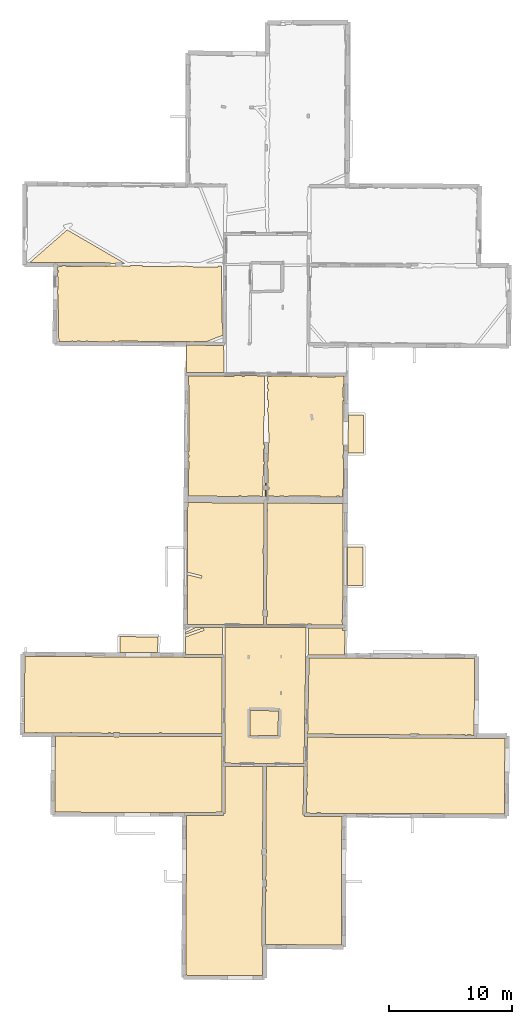
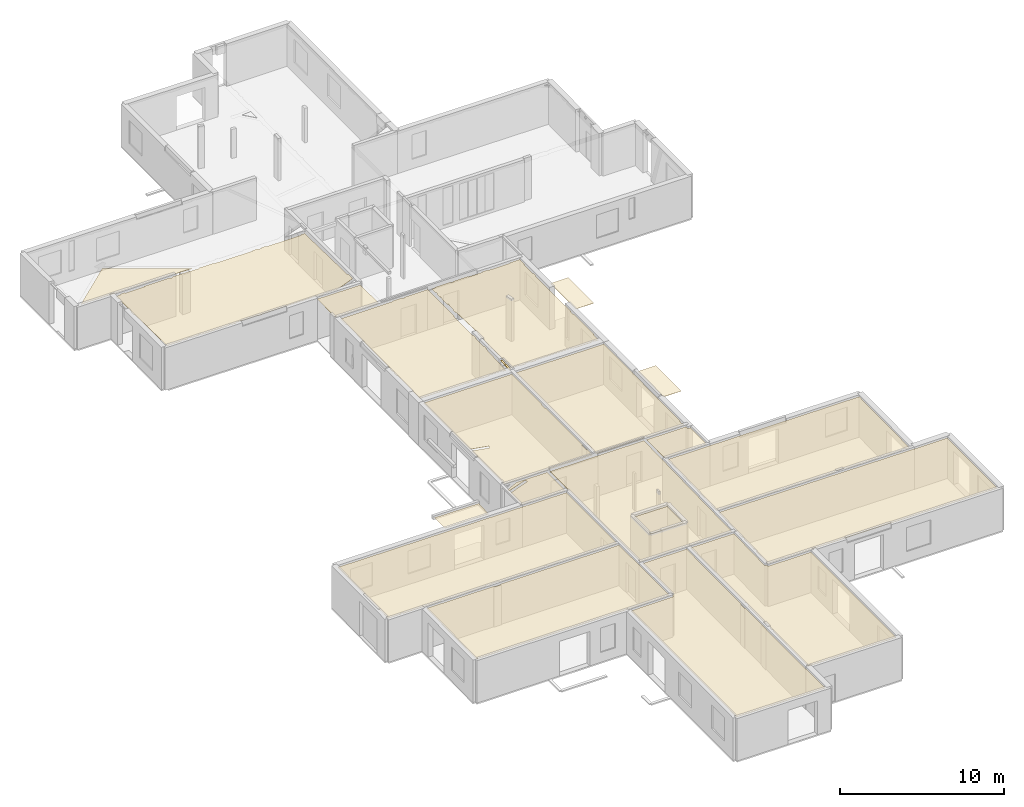
# One storey, part 10 of 14: 21 coverings.
"""IFC2X3 building model written with IfcOpenShell, lengths in metres."""

from ifc_helpers import new_model, entity, si_unit, converted_unit, derived_unit, direction, frame, origin, origin_with_axes, place, context, subcontext, project, spatial, polyline, outline, extrude, material, layer, layer_set, layer_usage, type_object, element, save


model = new_model("IFC2X3")

# Units and contexts
model_context = context("Model", 3, precision=1e-05, world=origin(), true_north=direction((0.0, 1.0)))
body_context = subcontext(model_context, "Body", "Model", "MODEL_VIEW")
ifc_project = project(units=[si_unit("LENGTHUNIT", "METRE"), si_unit("AREAUNIT", "SQUARE_METRE"), si_unit("VOLUMEUNIT", "CUBIC_METRE"), converted_unit("PLANEANGLEUNIT", "DEGREE", entity("IfcRatioMeasure", 0.0174532925199433), si_unit("PLANEANGLEUNIT", "RADIAN"), dimensions=[0, 0, 0, 0, 0, 0, 0]), si_unit("MASSUNIT", "GRAM", prefix="KILO"), derived_unit("MASSDENSITYUNIT", [(si_unit("MASSUNIT", "GRAM", prefix="KILO"), 1), (si_unit("LENGTHUNIT", "METRE"), -3)]), derived_unit("MOMENTOFINERTIAUNIT", [(si_unit("LENGTHUNIT", "METRE"), 4)]), si_unit("TIMEUNIT", "SECOND"), si_unit("FREQUENCYUNIT", "HERTZ"), si_unit("THERMODYNAMICTEMPERATUREUNIT", "DEGREE_CELSIUS"), derived_unit("THERMALTRANSMITTANCEUNIT", [(si_unit("MASSUNIT", "GRAM", prefix="KILO"), 1), (si_unit("THERMODYNAMICTEMPERATUREUNIT", "KELVIN"), -1), (si_unit("TIMEUNIT", "SECOND"), -3)]), derived_unit("VOLUMETRICFLOWRATEUNIT", [(si_unit("LENGTHUNIT", "METRE"), 3), (si_unit("TIMEUNIT", "SECOND"), -1)]), si_unit("ELECTRICCURRENTUNIT", "AMPERE"), si_unit("ELECTRICVOLTAGEUNIT", "VOLT"), si_unit("POWERUNIT", "WATT"), si_unit("FORCEUNIT", "NEWTON", prefix="KILO"), si_unit("ILLUMINANCEUNIT", "LUX"), si_unit("LUMINOUSFLUXUNIT", "LUMEN"), si_unit("LUMINOUSINTENSITYUNIT", "CANDELA"), derived_unit("USERDEFINED", [(si_unit("MASSUNIT", "GRAM", prefix="KILO"), -1), (si_unit("LENGTHUNIT", "METRE"), -2), (si_unit("TIMEUNIT", "SECOND"), 3), (si_unit("LUMINOUSFLUXUNIT", "LUMEN"), 1)]), derived_unit("LINEARVELOCITYUNIT", [(si_unit("LENGTHUNIT", "METRE"), 1), (si_unit("TIMEUNIT", "SECOND"), -1)]), si_unit("PRESSUREUNIT", "PASCAL"), derived_unit("USERDEFINED", [(si_unit("LENGTHUNIT", "METRE"), -2), (si_unit("MASSUNIT", "GRAM", prefix="KILO"), 1), (si_unit("TIMEUNIT", "SECOND"), -2)]), derived_unit("LINEARFORCEUNIT", [(si_unit("MASSUNIT", "GRAM", prefix="KILO"), 1), (si_unit("LENGTHUNIT", "METRE"), 1), (si_unit("TIMEUNIT", "SECOND"), -2), (si_unit("LENGTHUNIT", "METRE"), -1)]), derived_unit("PLANARFORCEUNIT", [(si_unit("MASSUNIT", "GRAM", prefix="KILO"), 1), (si_unit("LENGTHUNIT", "METRE"), 1), (si_unit("TIMEUNIT", "SECOND"), -2), (si_unit("LENGTHUNIT", "METRE"), -2)])], contexts=[model_context])

# Site, building, storey
placement = place(None, origin())
site = spatial("IfcSite", under=ifc_project, at=placement, CompositionType="ELEMENT")
building = spatial("IfcBuilding", under=site, at=placement, CompositionType="ELEMENT")
storey_placement = place(placement, frame((0.0, 0.0, 8.83152770996094)))
storey = spatial("IfcBuildingStorey", under=building, at=storey_placement, Name="Level 4", CompositionType="ELEMENT", Elevation=8.83152770996094)

# Coverings
ifc_material = material(Name="Covering default")
ifc_layer_1 = layer(ifc_material, 0.02)
ifc_layer_set_1 = layer_set([ifc_layer_1], Name="Covering : 20mm")
ifc_layer_usage_1 = layer_usage(ifc_layer_set_1, "AXIS3", "POSITIVE", 0.0)
covering_type_1 = type_object("IfcCoveringType", Name="Covering : 20mm", PredefinedType="CEILING")
covering_1_placement = place(placement, frame((0.0, 0.0, 11.8186979293823)))
element("IfcCovering", 1, at=covering_1_placement, inside=storey, type_object=covering_type_1, material=ifc_layer_usage_1, Name="Covering : 20mm", ObjectType="Covering : 20mm", PredefinedType="CEILING", context=body_context, shape_type="SweptSolid", body=[
    extrude(outline(polyline([(-0.155963897705078, 12.9070825576782), (2.83159446716309, 12.9335193634033), (2.83049011230469, 13.0585117340088), (2.95548820495605, 13.0584602355957), (2.95707321166992, 16.910701751709), (6.06137657165527, 16.894962310791), (6.02203750610352, 10.1598663330078), (5.96693229675293, 10.1598796844482), (5.96683120727539, 9.70976448059082), (6.0194091796875, 9.70975208282471), (5.97587585449219, 2.256667137146), (6.00043487548828, 2.25652360916138), (6.01150131225586, -0.0954488515853882), (-0.208127975463867, -0.060215950012207), (-0.155963897705078, 12.9070825576782)])), origin_with_axes(), (0.0, 0.0, 1.0), 0.02),
])
ifc_layer_2 = layer(ifc_material, 0.02)
ifc_layer_set_2 = layer_set([ifc_layer_2], Name="Covering : 20mm")
ifc_layer_usage_2 = layer_usage(ifc_layer_set_2, "AXIS3", "POSITIVE", 0.0)
covering_type_2 = type_object("IfcCoveringType", Name="Covering : 20mm", PredefinedType="CEILING")
covering_2_placement = place(placement, frame((0.0, 0.0, 11.8186979293823)))
element("IfcCovering", 2, at=covering_2_placement, inside=storey, type_object=covering_type_2, material=ifc_layer_usage_2, Name="Covering : 20mm", ObjectType="Covering : 20mm", PredefinedType="CEILING", context=body_context, shape_type="SweptSolid", body=[
    extrude(outline(polyline([(6.27205848693848, 6.73828887939453), (6.33028984069824, 6.74085998535156), (6.32365798950195, 6.89104843139648), (6.2729377746582, 6.88880920410156), (6.27441215515137, 7.14135360717773), (6.33842849731445, 7.14153099060059), (6.33696937561035, 7.66652870178223), (6.27747917175293, 7.66636371612549), (6.29000473022461, 9.81093883514404), (6.34920310974121, 9.81120872497559), (6.34751129150391, 10.1813430786133), (6.29216766357422, 10.1810903549194), (6.33137512207031, 16.8935928344727), (9.37964820861816, 16.8781394958496), (9.31031799316406, 12.9712085723877), (9.4402961730957, 12.9689025878906), (9.43974494934082, 12.838906288147), (12.454761505127, 12.8261156082153), (12.4285430908203, 2.39703178405762), (6.24689483642578, 2.43015265464783), (6.27205848693848, 6.73828887939453)])), origin_with_axes(), (0.0, 0.0, 1.0), 0.02),
])
ifc_layer_3 = layer(ifc_material, 0.02)
ifc_layer_set_3 = layer_set([ifc_layer_3], Name="Covering : 20mm")
ifc_layer_usage_3 = layer_usage(ifc_layer_set_3, "AXIS3", "POSITIVE", 0.0)
covering_type_3 = type_object("IfcCoveringType", Name="Covering : 20mm", PredefinedType="CEILING")
covering_3_placement = place(placement, frame((0.0, 0.0, 11.8186979293823)))
element("IfcCovering", 3, at=covering_3_placement, inside=storey, type_object=covering_type_3, material=ifc_layer_usage_3, Name="Covering : 20mm", ObjectType="Covering : 20mm", PredefinedType="CEILING", context=body_context, shape_type="SweptSolid", body=[
    extrude(outline(polyline([(9.59872245788574, 14.5694799423218), (9.65679931640625, 14.5681762695312), (9.66263389587402, 14.8281135559082), (9.60333442687988, 14.8294448852539), (9.62551307678223, 16.0792598724365), (9.68069076538086, 16.0780220031738), (9.68540191650391, 16.2879695892334), (9.62923812866211, 16.2892303466797), (9.6396369934082, 16.8751926422119), (9.6396369934082, 16.8751926422119), (9.68232154846191, 19.2805633544922), (23.3825645446777, 19.1745700836182), (23.3826789855957, 19.1582412719727), (25.6990547180176, 19.1746616363525), (25.6725120544434, 13.0359268188477), (12.6406917572021, 13.088828086853), (12.6406784057617, 13.0853290557861), (10.7439727783203, 13.0933752059937), (10.745096206665, 13.1433906555176), (10.4551696777344, 13.1499004364014), (10.4539279937744, 13.0946054458618), (9.57261657714844, 13.0983448028564), (9.59872245788574, 14.5694799423218)])), origin_with_axes(), (0.0, 0.0, 1.0), 0.02),
])
ifc_layer_4 = layer(ifc_material, 0.02)
ifc_layer_set_4 = layer_set([ifc_layer_4], Name="Covering : 20mm")
ifc_layer_usage_4 = layer_usage(ifc_layer_set_4, "AXIS3", "POSITIVE", 0.0)
covering_type_4 = type_object("IfcCoveringType", Name="Covering : 20mm", PredefinedType="CEILING")
covering_4_placement = place(placement, frame((0.0, 0.0, 11.8186979293823)))
element("IfcCovering", 4, at=covering_4_placement, inside=storey, type_object=covering_type_4, material=ifc_layer_usage_4, Name="Covering : 20mm", ObjectType="Covering : 20mm", PredefinedType="CEILING", context=body_context, shape_type="SweptSolid", body=[
    extrude(outline(polyline([(-10.81067943573, 19.3569412231445), (-6.06138038635254, 19.3415775299072), (-6.06136512756348, 19.2821311950684), (-5.62125015258789, 19.2822532653809), (-5.62126636505127, 19.3401546478271), (2.70806121826172, 19.3132095336914), (2.70707321166992, 16.9113903045654), (2.70553970336914, 13.1824140548706), (0.276535034179688, 13.1609201431274), (-10.8574066162109, 13.1824493408203), (-10.81067943573, 19.3569412231445)])), origin_with_axes(), (0.0, 0.0, 1.0), 0.02),
])
ifc_layer_5 = layer(ifc_material, 0.02)
ifc_layer_set_5 = layer_set([ifc_layer_5], Name="Covering : 20mm")
ifc_layer_usage_5 = layer_usage(ifc_layer_set_5, "AXIS3", "POSITIVE", 0.0)
covering_type_5 = type_object("IfcCoveringType", Name="Covering : 20mm", PredefinedType="CEILING")
covering_5_placement = place(placement, frame((0.0, 0.0, 11.8186979293823)))
element("IfcCovering", 5, at=covering_5_placement, inside=storey, type_object=covering_type_5, material=ifc_layer_usage_5, Name="Covering : 20mm", ObjectType="Covering : 20mm", PredefinedType="CEILING", context=body_context, shape_type="SweptSolid", body=[
    extrude(outline(polyline([(2.96075439453125, 25.868558883667), (2.98182487487793, 25.8685779571533), (2.97969818115234, 28.1927013397217), (9.56144332885742, 28.1640510559082), (9.38408279418945, 17.1281185150146), (2.95717620849609, 17.1607036590576), (2.96075439453125, 25.868558883667)])), origin_with_axes(), (0.0, 0.0, 1.0), 0.02),
])
ifc_layer_6 = layer(ifc_material, 0.02)
ifc_layer_set_6 = layer_set([ifc_layer_6], Name="Covering : 20mm")
ifc_layer_usage_6 = layer_usage(ifc_layer_set_6, "AXIS3", "POSITIVE", 0.0)
covering_type_6 = type_object("IfcCoveringType", Name="Covering : 20mm", PredefinedType="CEILING")
covering_6_placement = place(placement, frame((0.0, 0.0, 11.8186979293823)))
element("IfcCovering", 6, at=covering_6_placement, inside=storey, type_object=covering_type_6, material=ifc_layer_usage_6, Name="Covering : 20mm", ObjectType="Covering : 20mm", PredefinedType="CEILING", context=body_context, shape_type="SweptSolid", body=[
    extrude(outline(polyline([(5.00181007385254, 21.4414443969727), (7.30773162841797, 21.4125595092773), (7.27487182617188, 19.4015445709229), (5.64736175537109, 19.4281883239746), (5.64658546447754, 19.3807334899902), (4.9884204864502, 19.3916854858398), (5.00181007385254, 21.4414443969727)])), origin_with_axes(), (0.0, 0.0, 1.0), 0.02),
])
ifc_layer_7 = layer(ifc_material, 0.02)
ifc_layer_set_7 = layer_set([ifc_layer_7], Name="Covering : 20mm")
ifc_layer_usage_7 = layer_usage(ifc_layer_set_7, "AXIS3", "POSITIVE", 0.0)
covering_type_7 = type_object("IfcCoveringType", Name="Covering : 20mm", PredefinedType="CEILING")
covering_7_placement = place(placement, frame((0.0, 0.0, 11.8186979293823)))
element("IfcCovering", 7, at=covering_7_placement, inside=storey, type_object=covering_type_7, material=ifc_layer_usage_7, Name="Covering : 20mm", ObjectType="Covering : 20mm", PredefinedType="CEILING", context=body_context, shape_type="SweptSolid", body=[
    extrude(outline(polyline([(9.7962532043457, 25.7008686065674), (14.1999778747559, 25.6868343353271), (14.1999797821045, 25.6868343353271), (23.2475814819336, 25.6515769958496), (23.196662902832, 19.4260158538818), (22.9592170715332, 19.4278526306152), (22.9604072570801, 19.4808349609375), (22.6604804992676, 19.4875679016113), (22.6591911315918, 19.4301738739014), (22.4491806030273, 19.4317989349365), (22.4503135681152, 19.4822864532471), (22.1803779602051, 19.4883460998535), (22.1791572570801, 19.4338874816895), (21.3607063293457, 19.4402198791504), (21.3603591918945, 19.496753692627), (21.0102233886719, 19.4946098327637), (21.0105400085449, 19.4429302215576), (18.7023429870605, 19.460786819458), (18.7101287841797, 19.5162391662598), (18.5406227111816, 19.5400466918945), (18.5410270690918, 19.5429286956787), (18.0117454528809, 19.5519466400146), (18.0102844238281, 19.4661407470703), (11.6514549255371, 19.5153369903564), (11.6496639251709, 19.5747108459473), (11.4594860076904, 19.568977355957), (11.4610595703125, 19.516809463501), (9.68675804138184, 19.5305366516113), (9.7962532043457, 25.7008686065674)])), origin_with_axes(), (0.0, 0.0, 1.0), 0.02),
])
ifc_layer_8 = layer(ifc_material, 0.02)
ifc_layer_set_8 = layer_set([ifc_layer_8], Name="Covering : 20mm")
ifc_layer_usage_8 = layer_usage(ifc_layer_set_8, "AXIS3", "POSITIVE", 0.0)
covering_type_8 = type_object("IfcCoveringType", Name="Covering : 20mm", PredefinedType="CEILING")
covering_8_placement = place(placement, frame((0.0, 0.0, 11.8186979293823)))
element("IfcCovering", 8, at=covering_8_placement, inside=storey, type_object=covering_type_8, material=ifc_layer_usage_8, Name="Covering : 20mm", ObjectType="Covering : 20mm", PredefinedType="CEILING", context=body_context, shape_type="SweptSolid", body=[
    extrude(outline(polyline([(-13.3229026794434, 20.5661697387695), (-13.326681137085, 20.5662136077881), (-13.3170280456543, 21.3954544067383), (-13.3170280456543, 21.3954544067383), (-13.304967880249, 22.4314136505127), (-13.3096876144409, 22.431468963623), (-13.2855701446533, 25.8356418609619), (-0.348600387573242, 25.7713623046875), (-0.348663330078125, 25.7620182037354), (2.71070289611816, 25.7442874908447), (2.70816230773926, 19.5632095336914), (-2.18372440338135, 19.5790348052979), (-2.18246364593506, 19.6351623535156), (-2.35242080688477, 19.6389770507812), (-2.3537540435791, 19.5795841217041), (-5.59330368041992, 19.5900650024414), (-5.59317684173584, 19.6417121887207), (-6.09327411651611, 19.6429386138916), (-6.09340000152588, 19.591682434082), (-6.32446670532227, 19.5924301147461), (-6.32321643829346, 19.648099899292), (-6.4931755065918, 19.6519165039062), (-6.49449872970581, 19.5929794311523), (-9.44502830505371, 19.6025238037109), (-9.44377994537354, 19.6581382751465), (-9.62373447418213, 19.6621780395508), (-9.62506103515625, 19.6031074523926), (-10.9849128723145, 19.6075057983398), (-10.9849081039429, 19.6135864257812), (-12.2721118927002, 19.6145000457764), (-12.2741870880127, 19.6716651916504), (-12.4443702697754, 19.6654853820801), (-12.4425230026245, 19.6146202087402), (-13.3296403884888, 19.6152496337891), (-13.3229026794434, 20.5661697387695)])), origin_with_axes(), (0.0, 0.0, 1.0), 0.02),
])
ifc_layer_9 = layer(ifc_material, 0.02)
ifc_layer_set_9 = layer_set([ifc_layer_9], Name="Covering : 20mm")
ifc_layer_usage_9 = layer_usage(ifc_layer_set_9, "AXIS3", "POSITIVE", 0.0)
covering_type_9 = type_object("IfcCoveringType", Name="Covering : 20mm", PredefinedType="CEILING")
covering_9_placement = place(placement, frame((0.0, 0.0, 11.8186979293823)))
element("IfcCovering", 9, at=covering_9_placement, inside=storey, type_object=covering_type_9, material=ifc_layer_usage_9, Name="Covering : 20mm", ObjectType="Covering : 20mm", PredefinedType="CEILING", context=body_context, shape_type="SweptSolid", body=[
    extrude(outline(polyline([(9.76144981384277, 28.1631813049316), (12.5226249694824, 28.1511631011963), (12.5216178894043, 27.9413242340088), (12.7016181945801, 27.9404602050781), (12.6920166015625, 25.9410209655762), (9.73227882385254, 25.9510879516602), (9.76144981384277, 28.1631813049316)])), origin_with_axes(), (0.0, 0.0, 1.0), 0.02),
])
ifc_layer_10 = layer(ifc_material, 0.02)
ifc_layer_set_10 = layer_set([ifc_layer_10], Name="Covering : 20mm")
ifc_layer_usage_10 = layer_usage(ifc_layer_set_10, "AXIS3", "POSITIVE", 0.0)
covering_type_10 = type_object("IfcCoveringType", Name="Covering : 20mm", PredefinedType="CEILING")
covering_10_placement = place(placement, frame((0.0, 0.0, 11.8186979293823)))
element("IfcCovering", 10, at=covering_10_placement, inside=storey, type_object=covering_type_10, material=ifc_layer_usage_10, Name="Covering : 20mm", ObjectType="Covering : 20mm", PredefinedType="CEILING", context=body_context, shape_type="SweptSolid", body=[
    extrude(outline(polyline([(-0.253894805908203, 27.4120845794678), (1.26633834838867, 27.9529819488525), (1.19929504394531, 28.1414108276367), (-0.253332138061523, 27.6245670318604), (-0.252902984619141, 27.7869739532471), (0.627913475036621, 28.202938079834), (2.77969741821289, 28.1935710906982), (2.78170967102051, 25.9939556121826), (-0.257606506347656, 26.0082588195801), (-0.253894805908203, 27.4120845794678)])), origin_with_axes(), (0.0, 0.0, 1.0), 0.02),
])
ifc_layer_11 = layer(ifc_material, 0.02)
ifc_layer_set_11 = layer_set([ifc_layer_11], Name="Covering : 20mm")
ifc_layer_usage_11 = layer_usage(ifc_layer_set_11, "AXIS3", "POSITIVE", 0.0)
covering_type_11 = type_object("IfcCoveringType", Name="Covering : 20mm", PredefinedType="CEILING")
covering_11_placement = place(placement, frame((0.0, 0.0, 11.8186979293823)))
element("IfcCovering", 11, at=covering_11_placement, inside=storey, type_object=covering_type_11, material=ifc_layer_usage_11, Name="Covering : 20mm", ObjectType="Covering : 20mm", PredefinedType="CEILING", context=body_context, shape_type="SweptSolid", body=[
    extrude(outline(polyline([(-5.56164360046387, 27.446361541748), (-2.47794914245605, 27.4143123626709), (-2.50628566741943, 26.1520862579346), (-5.57108402252197, 26.1673145294189), (-5.56164360046387, 27.446361541748)])), origin_with_axes(), (0.0, 0.0, 1.0), 0.02),
])
ifc_layer_12 = layer(ifc_material, 0.02)
ifc_layer_set_12 = layer_set([ifc_layer_12], Name="Covering : 20mm")
ifc_layer_usage_12 = layer_usage(ifc_layer_set_12, "AXIS3", "POSITIVE", 0.0)
covering_type_12 = type_object("IfcCoveringType", Name="Covering : 20mm", PredefinedType="CEILING")
covering_12_placement = place(placement, frame((0.0, 0.0, 11.8186979293823)))
element("IfcCovering", 12, at=covering_12_placement, inside=storey, type_object=covering_type_12, material=ifc_layer_usage_12, Name="Covering : 20mm", ObjectType="Covering : 20mm", PredefinedType="CEILING", context=body_context, shape_type="SweptSolid", body=[
    extrude(outline(polyline([(6.35177612304688, 29.0747890472412), (6.41155433654785, 29.0746650695801), (6.41255378723145, 29.5647678375244), (6.35304832458496, 29.5648899078369), (6.37395286560059, 37.6245307922363), (6.43348693847656, 37.6263275146484), (6.42775344848633, 37.8165054321289), (6.37444686889648, 37.8148994445801), (6.37568855285645, 38.2935676574707), (12.5711727142334, 38.2620429992676), (12.5259799957275, 28.8497943878174), (12.4680080413818, 28.8486804962158), (12.4726181030273, 28.6085186004639), (12.5248260498047, 28.6095218658447), (12.5237770080566, 28.3911590576172), (9.97736167907715, 28.4022445678711), (9.9785327911377, 28.4544525146484), (9.66630172729492, 28.461462020874), (9.66500282287598, 28.4036026000977), (6.35007286071777, 28.4180316925049), (6.35177612304688, 29.0747890472412)])), origin_with_axes(), (0.0, 0.0, 1.0), 0.02),
])
ifc_layer_13 = layer(ifc_material, 0.02)
ifc_layer_set_13 = layer_set([ifc_layer_13], Name="Covering : 20mm")
ifc_layer_usage_13 = layer_usage(ifc_layer_set_13, "AXIS3", "POSITIVE", 0.0)
covering_type_13 = type_object("IfcCoveringType", Name="Covering : 20mm", PredefinedType="CEILING")
covering_13_placement = place(placement, frame((0.0, 0.0, 11.8186979293823)))
element("IfcCovering", 13, at=covering_13_placement, inside=storey, type_object=covering_type_13, material=ifc_layer_usage_13, Name="Covering : 20mm", ObjectType="Covering : 20mm", PredefinedType="CEILING", context=body_context, shape_type="SweptSolid", body=[
    extrude(outline(polyline([(-0.0705327987670898, 32.4649963378906), (1.04975509643555, 32.1874237060547), (1.09785461425781, 32.3815536499023), (-0.0699882507324219, 32.6709060668945), (-0.0550336837768555, 38.3262901306152), (6.12569046020508, 38.2948379516602), (6.11611366271973, 34.6026878356934), (6.06555938720703, 34.6038246154785), (6.05523681640625, 34.1439399719238), (6.11491966247559, 34.1426010131836), (6.10319709777832, 29.6228675842285), (6.04376792907715, 29.6230583190918), (6.04209518432617, 29.1029644012451), (6.10184669494629, 29.1027717590332), (6.10007286071777, 28.4191207885742), (-0.0811595916748047, 28.4460258483887), (-0.0705327987670898, 32.4649963378906)])), origin_with_axes(), (0.0, 0.0, 1.0), 0.02),
])
ifc_layer_14 = layer(ifc_material, 0.02)
ifc_layer_set_14 = layer_set([ifc_layer_14], Name="Covering : 20mm")
ifc_layer_usage_14 = layer_usage(ifc_layer_set_14, "AXIS3", "POSITIVE", 0.0)
covering_type_14 = type_object("IfcCoveringType", Name="Covering : 20mm", PredefinedType="CEILING")
covering_14_placement = place(placement, frame((0.0, 0.0, 11.8186979293823)))
element("IfcCovering", 14, at=covering_14_placement, inside=storey, type_object=covering_type_14, material=ifc_layer_usage_14, Name="Covering : 20mm", ObjectType="Covering : 20mm", PredefinedType="CEILING", context=body_context, shape_type="SweptSolid", body=[
    extrude(outline(polyline([(12.934103012085, 34.7059059143066), (14.1822776794434, 34.7071304321289), (14.1731395721436, 31.5940799713135), (12.9191722869873, 31.596227645874), (12.934103012085, 34.7059059143066)])), origin_with_axes(), (0.0, 0.0, 1.0), 0.02),
])
ifc_layer_15 = layer(ifc_material, 0.02)
ifc_layer_set_15 = layer_set([ifc_layer_15], Name="Covering : 20mm")
ifc_layer_usage_15 = layer_usage(ifc_layer_set_15, "AXIS3", "POSITIVE", 0.0)
covering_type_15 = type_object("IfcCoveringType", Name="Covering : 20mm", PredefinedType="CEILING")
covering_15_placement = place(placement, frame((0.0, 0.0, 11.8186979293823)))
element("IfcCovering", 15, at=covering_15_placement, inside=storey, type_object=covering_type_15, material=ifc_layer_usage_15, Name="Covering : 20mm", ObjectType="Covering : 20mm", PredefinedType="CEILING", context=body_context, shape_type="SweptSolid", body=[
    extrude(outline(polyline([(6.38441848754883, 41.6593704223633), (6.44395446777344, 41.6571044921875), (6.46832847595215, 42.2970542907715), (6.48248863220215, 42.2969131469727), (6.49119567871094, 43.1635208129883), (6.54782485961914, 43.1651573181152), (6.47463989257812, 45.697437286377), (6.42453193664551, 45.695987701416), (6.4252758026123, 46.0077819824219), (6.48159790039062, 46.0073585510254), (6.48663711547852, 46.6774139404297), (6.4268741607666, 46.677864074707), (6.42850112915039, 47.3588905334473), (6.48190307617188, 47.3576927185059), (6.48616790771484, 47.5476455688477), (6.428955078125, 47.5489311218262), (6.42990875244141, 47.9490051269531), (6.48514556884766, 47.9477653503418), (6.48896217346191, 48.1177253723145), (6.4303150177002, 48.1190414428711), (6.43136405944824, 48.5586242675781), (6.73922538757324, 48.5722236633301), (6.73690795898438, 48.6246948242188), (7.77781105041504, 48.618766784668), (7.77918815612793, 48.5588798522949), (7.99935722351074, 48.5639419555664), (7.99812507629395, 48.6175155639648), (8.99018478393555, 48.6118659973145), (8.98955535888672, 48.5617141723633), (9.99952697753906, 48.5490455627441), (10.0002422332764, 48.6061172485352), (10.3501815795898, 48.6041259765625), (10.3496627807617, 48.5511856079102), (11.9297142028809, 48.5357208251953), (11.9302959442139, 48.5951309204102), (12.6307621002197, 48.5911445617676), (12.6278305053711, 47.9803733825684), (12.5774269104004, 47.9810447692871), (12.5627384185791, 46.8810997009277), (12.6225490570068, 46.8803024291992), (12.6212062835693, 46.6007843017578), (12.5664520263672, 46.600944519043), (12.5560874938965, 43.0202713012695), (12.5940189361572, 43.0201606750488), (12.5903129577637, 42.2483329772949), (12.5387840270996, 42.2494888305664), (12.5322971343994, 41.9605407714844), (12.588924407959, 41.9592704772949), (12.5767803192139, 39.4298400878906), (12.5255012512207, 39.4300575256348), (12.5227832794189, 38.7922973632812), (12.2511520385742, 38.7936782836914), (12.252326965332, 38.8460426330566), (12.0323829650879, 38.8509788513184), (12.0311222076416, 38.7947998046875), (10.7320671081543, 38.8014068603516), (10.7322597503662, 38.8601608276367), (8.12179565429688, 38.8687515258789), (8.12161827087402, 38.8146896362305), (7.77053451538086, 38.816478729248), (7.77165985107422, 38.8666076660156), (7.41175079345703, 38.8746871948242), (7.41048622131348, 38.8183097839355), (6.95042037963867, 38.8206520080566), (6.95164108276367, 38.8750152587891), (6.47722434997559, 38.8856658935547), (6.47849464416504, 39.3757553100586), (6.53274726867676, 39.3745384216309), (6.53768539428711, 39.5944862365723), (6.47906684875488, 39.5958023071289), (6.43609809875488, 41.3071937561035), (6.38350105285645, 41.3057479858398), (6.38441848754883, 41.6593704223633)])), origin_with_axes(), (0.0, 0.0, 1.0), 0.02),
])
ifc_layer_16 = layer(ifc_material, 0.02)
ifc_layer_set_16 = layer_set([ifc_layer_16], Name="Covering : 20mm")
ifc_layer_usage_16 = layer_usage(ifc_layer_set_16, "AXIS3", "POSITIVE", 0.0)
covering_type_16 = type_object("IfcCoveringType", Name="Covering : 20mm", PredefinedType="CEILING")
covering_16_placement = place(placement, frame((0.0, 0.0, 11.8186979293823)))
element("IfcCovering", 16, at=covering_16_placement, inside=storey, type_object=covering_type_16, material=ifc_layer_usage_16, Name="Covering : 20mm", ObjectType="Covering : 20mm", PredefinedType="CEILING", context=body_context, shape_type="SweptSolid", body=[
    extrude(outline(polyline([(6.25674247741699, 39.9030418395996), (6.37986183166504, 39.9027214050293), (6.37907218933105, 39.5980491638184), (6.33773422241211, 39.5989761352539), (6.33279800415039, 39.3790283203125), (6.37850189208984, 39.378002166748), (6.3770637512207, 38.8235664367676), (6.21977615356445, 38.8243675231934), (6.25674247741699, 39.9030418395996)])), origin_with_axes(), (0.0, 0.0, 1.0), 0.02),
])
ifc_layer_17 = layer(ifc_material, 0.02)
ifc_layer_set_17 = layer_set([ifc_layer_17], Name="Covering : 20mm")
ifc_layer_usage_17 = layer_usage(ifc_layer_set_17, "AXIS3", "POSITIVE", 0.0)
covering_type_17 = type_object("IfcCoveringType", Name="Covering : 20mm", PredefinedType="CEILING")
covering_17_placement = place(placement, frame((0.0, 0.0, 11.8186979293823)))
element("IfcCovering", 17, at=covering_17_placement, inside=storey, type_object=covering_type_17, material=ifc_layer_usage_17, Name="Covering : 20mm", ObjectType="Covering : 20mm", PredefinedType="CEILING", context=body_context, shape_type="SweptSolid", body=[
    extrude(outline(polyline([(-0.0215635299682617, 42.0023002624512), (0.0300579071044922, 42.0011405944824), (0.0343227386474609, 42.1910972595215), (-0.0205087661743164, 42.1923294067383), (-0.0190153121948242, 42.4612693786621), (0.0403823852539062, 42.4610290527344), (0.0622749328613281, 47.891902923584), (0.0111398696899414, 47.8921089172363), (0.0150260925292969, 48.5920448303223), (3.6988697052002, 48.590461730957), (3.69882774353027, 48.6419868469238), (4.3401050567627, 48.6383361816406), (4.33893203735352, 48.5860977172852), (4.55887603759766, 48.5811576843262), (4.56013107299805, 48.6370849609375), (6.1815299987793, 48.6278533935547), (6.17376518249512, 45.3753128051758), (6.1173210144043, 45.375373840332), (6.11479187011719, 43.0348434448242), (6.16988563537598, 43.034782409668), (6.1663761138916, 42.6853408813477), (6.10693550109863, 42.684928894043), (6.11403656005859, 41.6645126342773), (6.16443061828613, 41.6648635864258), (6.16377639770508, 41.4126777648926), (6.10842514038086, 41.4145736694336), (6.01969528198242, 38.8253898620605), (5.81131744384766, 38.8264503479004), (5.81148147583008, 38.8806037902832), (4.78129005432129, 38.8837242126465), (4.7811336517334, 38.8316917419434), (4.30005836486816, 38.8341407775879), (4.30118751525879, 38.8844985961914), (4.10123634338379, 38.8889846801758), (4.10002899169922, 38.8351593017578), (0.000753402709960938, 38.856014251709), (0.0322017669677734, 41.651008605957), (-0.0235109329223633, 41.6516342163086), (-0.0215635299682617, 42.0023002624512)])), origin_with_axes(), (0.0, 0.0, 1.0), 0.02),
])
ifc_layer_18 = layer(ifc_material, 0.02)
ifc_layer_set_18 = layer_set([ifc_layer_18], Name="Covering : 20mm")
ifc_layer_usage_18 = layer_usage(ifc_layer_set_18, "AXIS3", "POSITIVE", 0.0)
covering_type_18 = type_object("IfcCoveringType", Name="Covering : 20mm", PredefinedType="CEILING")
covering_18_placement = place(placement, frame((0.0, 0.0, 11.8186979293823)))
element("IfcCovering", 18, at=covering_18_placement, inside=storey, type_object=covering_type_18, material=ifc_layer_usage_18, Name="Covering : 20mm", ObjectType="Covering : 20mm", PredefinedType="CEILING", context=body_context, shape_type="SweptSolid", body=[
    extrude(outline(polyline([(12.9797973632812, 44.2234992980957), (12.9797954559326, 44.2234992980957), (12.9857368469238, 45.4609375), (14.2335739135742, 45.4543952941895), (14.2154788970947, 42.3364448547363), (12.9707794189453, 42.3449783325195), (12.9797973632812, 44.2234992980957)])), origin_with_axes(), (0.0, 0.0, 1.0), 0.02),
])
ifc_layer_19 = layer(ifc_material, 0.02)
ifc_layer_set_19 = layer_set([ifc_layer_19], Name="Covering : 20mm")
ifc_layer_usage_19 = layer_usage(ifc_layer_set_19, "AXIS3", "POSITIVE", 0.0)
covering_type_19 = type_object("IfcCoveringType", Name="Covering : 20mm", PredefinedType="CEILING")
covering_19_placement = place(placement, frame((0.0, 0.0, 11.8186979293823)))
element("IfcCovering", 19, at=covering_19_placement, inside=storey, type_object=covering_type_19, material=ifc_layer_usage_19, Name="Covering : 20mm", ObjectType="Covering : 20mm", PredefinedType="CEILING", context=body_context, shape_type="SweptSolid", body=[
    extrude(outline(polyline([(-0.137153625488281, 51.1205558776855), (2.8642406463623, 51.096752166748), (2.88747787475586, 48.8966064453125), (-0.153188705444336, 48.9139137268066), (-0.137153625488281, 51.1205558776855)])), origin_with_axes(), (0.0, 0.0, 1.0), 0.02),
])
ifc_layer_20 = layer(ifc_material, 0.02)
ifc_layer_set_20 = layer_set([ifc_layer_20], Name="Covering : 20mm")
ifc_layer_usage_20 = layer_usage(ifc_layer_set_20, "AXIS3", "POSITIVE", 0.0)
covering_type_20 = type_object("IfcCoveringType", Name="Covering : 20mm", PredefinedType="CEILING")
covering_20_placement = place(placement, frame((0.0, 0.0, 11.8186979293823)))
element("IfcCovering", 20, at=covering_20_placement, inside=storey, type_object=covering_type_20, material=ifc_layer_usage_20, Name="Covering : 20mm", ObjectType="Covering : 20mm", PredefinedType="CEILING", context=body_context, shape_type="SweptSolid", body=[
    extrude(outline(polyline([(-10.6452970504761, 55.6330490112305), (-10.5866737365723, 55.6328506469727), (-10.5831050872803, 56.6830368041992), (-10.6348361968994, 56.6832122802734), (-10.6317377090454, 56.9942054748535), (-10.5761470794678, 56.9929580688477), (-10.5716590881348, 57.1929054260254), (-10.6297454833984, 57.1942100524902), (-10.6269226074219, 57.4775543212891), (-10.2643280029297, 57.5160903930664), (-10.2697830200195, 57.5674171447754), (-9.93441009521484, 57.5666389465332), (-9.93441390991211, 57.5086822509766), (-8.59407711029053, 57.5086059570312), (-8.59407424926758, 57.5635299682617), (-6.79248237609863, 57.5593528747559), (-6.79362964630127, 57.5081939697266), (-6.61367893218994, 57.5041580200195), (-6.61245059967041, 57.5589332580566), (-5.97549343109131, 57.5574569702148), (-4.73903560638428, 57.5218696594238), (-4.73747253417969, 57.5761947631836), (-3.73220825195312, 57.5695953369141), (-3.73260688781738, 57.5195007324219), (-0.972404479980469, 57.4975433349609), (-0.971975326538086, 57.5514678955078), (-0.623442649841309, 57.5491790771484), (-0.622491836547852, 57.4896926879883), (-0.362333297729492, 57.4938507080078), (-0.363190650939941, 57.5474700927734), (-0.0720548629760742, 57.5455589294434), (-0.0724067687988281, 57.4873428344727), (2.38787269592285, 57.4721221923828), (2.38846015930176, 57.5293998718262), (2.66714286804199, 57.5275688171387), (2.7544116973877, 52.4126205444336), (2.81348609924316, 52.4136276245117), (2.81087112426758, 51.924919128418), (1.45715808868408, 51.401481628418), (0.451644897460938, 51.4240531921387), (0.450339317321777, 51.3659057617188), (0.141364097595215, 51.3683547973633), (0.141498565673828, 51.421012878418), (-3.8792839050293, 51.4312553405762), (-3.87942409515381, 51.3761177062988), (-4.09944629669189, 51.3771820068359), (-4.09922790527344, 51.4361953735352), (-5.69949722290039, 51.4421119689941), (-5.69970846176147, 51.384937286377), (-6.00082540512085, 51.3863945007324), (-5.99964904785156, 51.4388465881348), (-6.18959903717041, 51.4431076049805), (-6.19085025787354, 51.3873176574707), (-8.14113235473633, 51.3967666625977), (-8.14000797271729, 51.4468841552734), (-8.30996322631836, 51.4506988525391), (-8.31115531921387, 51.397590637207), (-8.78122425079346, 51.3998680114746), (-8.78007030487061, 51.4512481689453), (-9.06999778747559, 51.4577598571777), (-9.07126617431641, 51.4012756347656), (-9.36130523681641, 51.4026794433594), (-9.36014652252197, 51.4542694091797), (-9.51010990142822, 51.4576377868652), (-9.51132774353027, 51.4034042358398), (-10.5294151306152, 51.4083404541016), (-10.5949764251709, 55.2629432678223), (-10.6489934921265, 55.2620239257812), (-10.6452970504761, 55.6330490112305)])), origin_with_axes(), (0.0, 0.0, 1.0), 0.02),
])
ifc_layer_21 = layer(ifc_material, 0.02)
ifc_layer_set_21 = layer_set([ifc_layer_21], Name="Covering : 20mm")
ifc_layer_usage_21 = layer_usage(ifc_layer_set_21, "AXIS3", "POSITIVE", 0.0)
covering_type_21 = type_object("IfcCoveringType", Name="Covering : 20mm", PredefinedType="CEILING")
covering_21_placement = place(placement, frame((0.0, 0.0, 11.8186979293823)))
element("IfcCovering", 21, at=covering_21_placement, inside=storey, type_object=covering_type_21, material=ifc_layer_usage_21, Name="Covering : 20mm", ObjectType="Covering : 20mm", PredefinedType="CEILING", context=body_context, shape_type="SweptSolid", body=[
    extrude(outline(polyline([(-12.8901834487915, 57.824951171875), (-9.84803867340088, 60.4802627563477), (-5.12626075744629, 57.733097076416), (-6.34641695022583, 57.7682151794434), (-6.36147832870483, 57.8083534240723), (-12.8901834487915, 57.824951171875)])), origin_with_axes(), (0.0, 0.0, 1.0), 0.02),
])

save(model, "model.ifc")
